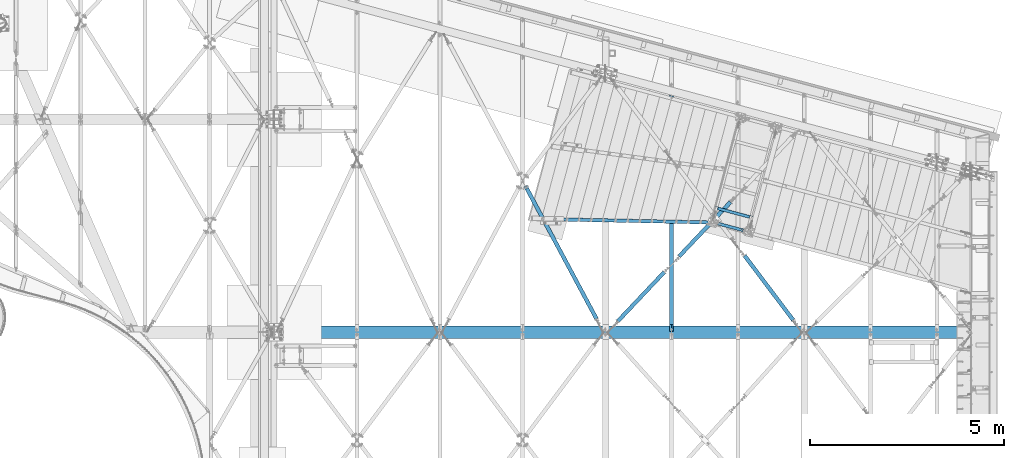
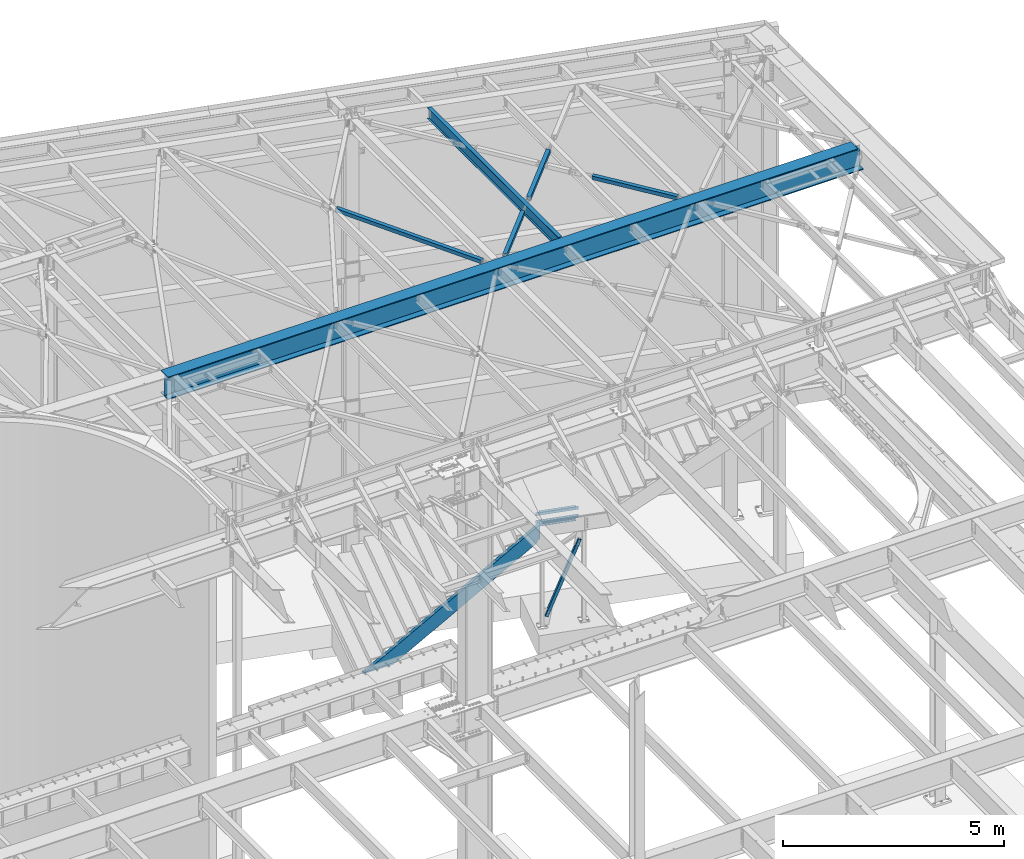
# One storey, part 1167 of 1763: 8 beams, 2 members, 9 elements without a shape of their own.
"""IFC2X3 building model written with IfcOpenShell, lengths in millimetres."""

import ifcopenshell
import ifcopenshell.guid

model = None  # the IFC model being written
_history = None  # IfcOwnerHistory: only IFC2X3 demands one
_inside = {}  # id of a spatial element -> (the spatial element, [elements in it])
_under = {}  # id of a project, library or spatial element -> (it, [spatial elements below it])
_declared = {}  # id of a project -> (the project, [libraries it declares])
_typed = {}  # id of a type object -> (the type object, [elements of that type])
_made_of = {}  # id of a material, layer set ... -> (it, [elements and type objects made of it])


def new_model(schema):
    """Start an empty IFC model of exactly this schema.

    Asked for "IFC4X3", IfcOpenShell would pick the latest addendum, in which some entities
    have other attributes; the version numbers below select the first issue.
    IFC2X3 requires an IfcOwnerHistory on every rooted entity: one is made here for all.
    """
    global model, _history
    if schema == "IFC4X3":
        model = ifcopenshell.file(schema_version=(4, 3, 0, 0))
    else:
        model = ifcopenshell.file(schema=schema)
    _inside.clear()
    _under.clear()
    _declared.clear()
    _typed.clear()
    _made_of.clear()
    _history = None
    if model.schema == "IFC2X3":
        org = make("IfcOrganization", Name="unknown")
        user = make(
            "IfcPersonAndOrganization",
            ThePerson=make("IfcPerson", FamilyName="unknown"),
            TheOrganization=org,
        )
        app = make(
            "IfcApplication",
            ApplicationDeveloper=org,
            Version="unknown",
            ApplicationFullName="unknown",
            ApplicationIdentifier="unknown",
        )
        _history = make(
            "IfcOwnerHistory",
            OwningUser=user,
            OwningApplication=app,
            ChangeAction="ADDED",
            CreationDate=0,
        )
    return model


def make(cls, **values):
    """One entity of the class cls with the attributes given. An attribute that is None is left unset."""
    return model.create_entity(
        cls, **{name: value for name, value in values.items() if value is not None}
    )


def rooted(cls, **values):
    """An entity with a GlobalId (a new one), such as an element, a storey or a relation."""
    return make(cls, GlobalId=ifcopenshell.guid.new(), OwnerHistory=_history, **values)


def si_unit(unit_type, name, prefix=None):
    """IfcSIUnit, for example si_unit("LENGTHUNIT", "METRE", prefix="MILLI")."""
    return make("IfcSIUnit", UnitType=unit_type, Prefix=prefix, Name=name)


def assignment(units):
    """IfcUnitAssignment: the units of a project."""
    return None if units is None else make("IfcUnitAssignment", Units=units)


def point(xyz):
    """IfcCartesianPoint."""
    return None if xyz is None else make("IfcCartesianPoint", Coordinates=xyz)


def direction(xyz):
    """IfcDirection."""
    return None if xyz is None else make("IfcDirection", DirectionRatios=xyz)


def frame(location, z_axis=None, x_axis=None):
    """IfcAxis2Placement3D, a coordinate frame: its origin and axes. An axis left out is left unset."""
    return make(
        "IfcAxis2Placement3D",
        Location=point(location),
        Axis=direction(z_axis),
        RefDirection=direction(x_axis),
    )


def origin_with_axes():
    """The frame at (0, 0, 0) with the z axis (0, 0, 1) and the x axis (1, 0, 0) written out."""
    return frame((0.0, 0.0, 0.0), z_axis=(0.0, 0.0, 1.0), x_axis=(1.0, 0.0, 0.0))


def place(relative_to, where):
    """IfcLocalPlacement: puts the frame where relative to a parent placement (None: the world)."""
    return make(
        "IfcLocalPlacement", PlacementRelTo=relative_to, RelativePlacement=where
    )


def context(
    kind, dimensions, precision=None, world=None, true_north=None, identifier=None
):
    """IfcGeometricRepresentationContext, for example the 3D "Model" context."""
    return make(
        "IfcGeometricRepresentationContext",
        ContextIdentifier=identifier,
        ContextType=kind,
        CoordinateSpaceDimension=dimensions,
        Precision=precision,
        WorldCoordinateSystem=world,
        TrueNorth=true_north,
    )


def subcontext(parent, identifier, kind, view, scale=None):
    """IfcGeometricRepresentationSubContext, for example "Body" below "Model"."""
    return make(
        "IfcGeometricRepresentationSubContext",
        ContextIdentifier=identifier,
        ContextType=kind,
        ParentContext=parent,
        TargetScale=scale,
        TargetView=view,
    )


def project(units=None, contexts=None):
    """IfcProject with its units and contexts."""
    return rooted(
        "IfcProject",
        Name="project",
        RepresentationContexts=contexts,
        UnitsInContext=assignment(units),
    )


def spatial(cls, under=None, at=None, **own):
    """A site, building, storey or space (cls), placed at a placement, below another one or the project."""
    s = rooted(cls, ObjectPlacement=at, **own)
    if under is not None:
        _under.setdefault(under.id(), (under, []))[1].append(s)
    return s


def faces_of(points, faces, orient=None, outer=None):
    """IfcFace entities. A face is a list of loops; a loop is a list of indices into points, from 0.

    orient and outer hold one flag for each loop. By default every Orientation is true, the
    first loop of a face is its IfcFaceOuterBound and the others are IfcFaceBound.
    """
    made = []
    for i, loops in enumerate(faces):
        bounds = []
        for j, loop in enumerate(loops):
            is_outer = j == 0 if outer is None else outer[i][j]
            bounds.append(
                make(
                    "IfcFaceOuterBound" if is_outer else "IfcFaceBound",
                    Bound=make("IfcPolyLoop", Polygon=[points[k] for k in loop]),
                    Orientation=True if orient is None else orient[i][j],
                )
            )
        made.append(make("IfcFace", Bounds=bounds))
    return made


def faceted_brep(points, faces, orient=None, outer=None, voids=None):
    """IfcFacetedBrep: a solid bounded by flat faces; with voids (closed shells), ...WithVoids."""
    shared = [point(p) for p in points]
    hull = make("IfcClosedShell", CfsFaces=faces_of(shared, faces, orient, outer))
    if voids is None:
        return make("IfcFacetedBrep", Outer=hull)
    return make(
        "IfcFacetedBrepWithVoids",
        Outer=hull,
        Voids=[
            make(cls, CfsFaces=faces_of(shared, fs, o, b)) for cls, fs, o, b in voids
        ],
    )


def shape(context_of_items, identifier, shape_type, items):
    """IfcShapeRepresentation: the items that make up one representation, for example the "Body"."""
    return make(
        "IfcShapeRepresentation",
        ContextOfItems=context_of_items,
        RepresentationIdentifier=identifier,
        RepresentationType=shape_type,
        Items=items,
    )


def material(Name=None, Category=None):
    """IfcMaterial."""
    return make("IfcMaterial", Name=Name, Category=Category)


def made_of(thing, what):
    """Note that an element or type object is made of a material, layer set ...; save() writes the relation."""
    if what is not None:
        _made_of.setdefault(what.id(), (what, []))[1].append(thing)
    return thing


def type_object(cls, material=None, **own):
    """A type object (cls), such as IfcWallType, which elements share."""
    return made_of(rooted(cls, **own), material)


def element(
    cls,
    number,
    at=None,
    inside=None,
    cuts=None,
    type_object=None,
    material=None,
    context=None,
    identifier="Body",
    shape_type=None,
    held_by="IfcProductDefinitionShape",
    body=None,
    shapes=None,
    **own,
):
    """One element of the class cls, such as IfcWall. Its Tag is "e" and its number.

    at: its placement. inside: the storey or other place that contains it. cuts: it is an
    opening in that element (IfcRelVoidsElement). A single representation is given by context,
    identifier, shape_type and body (its items); several are given by shapes. held_by: the class
    of the entity that holds the representations. save() writes the other relations.
    """
    e = rooted(cls, Tag="e%d" % number, ObjectPlacement=at, **own)
    if body is not None:
        shapes = [shape(context, identifier, shape_type, body)]
    if shapes is not None:
        e.Representation = make(held_by, Representations=shapes)
    if inside is not None:
        _inside.setdefault(inside.id(), (inside, []))[1].append(e)
    if cuts is not None:
        rooted(
            "IfcRelVoidsElement", RelatingBuildingElement=cuts, RelatedOpeningElement=e
        )
    if type_object is not None:
        _typed.setdefault(type_object.id(), (type_object, []))[1].append(e)
    return made_of(e, material)


def aggregate(whole, parts):
    """IfcRelAggregates: a whole, such as a stair, and the parts it consists of."""
    return rooted("IfcRelAggregates", RelatingObject=whole, RelatedObjects=parts)


def save(model, path):
    """Write the relations noted so far, then the file.

    IfcRelAggregates (storeys below a building ...), IfcRelContainedInSpatialStructure (elements
    in a storey), IfcRelDefinesByType, IfcRelAssociatesMaterial and IfcRelDeclares: one each for
    every whole, place, type object, material and project.
    """
    for whole, parts in _under.values():
        aggregate(whole, parts)
    for where, things in _inside.values():
        rooted(
            "IfcRelContainedInSpatialStructure",
            RelatedElements=things,
            RelatingStructure=where,
        )
    for kind, things in _typed.values():
        rooted("IfcRelDefinesByType", RelatedObjects=things, RelatingType=kind)
    for what, things in _made_of.values():
        rooted("IfcRelAssociatesMaterial", RelatedObjects=things, RelatingMaterial=what)
    for by, libraries in _declared.values():
        rooted("IfcRelDeclares", RelatingContext=by, RelatedDefinitions=libraries)
    model.write(path)


model = new_model("IFC2X3")

# Units and contexts
model_context = context("Model", 3, precision=1e-05, world=origin_with_axes())
body_context = subcontext(model_context, "Body", "Model", "MODEL_VIEW")
ifc_project = project(units=[si_unit("LENGTHUNIT", "METRE", prefix="MILLI"), si_unit("AREAUNIT", "SQUARE_METRE"), si_unit("VOLUMEUNIT", "CUBIC_METRE"), si_unit("MASSUNIT", "GRAM", prefix="KILO"), si_unit("TIMEUNIT", "SECOND"), si_unit("PLANEANGLEUNIT", "RADIAN"), si_unit("SOLIDANGLEUNIT", "STERADIAN"), si_unit("THERMODYNAMICTEMPERATUREUNIT", "DEGREE_CELSIUS"), si_unit("LUMINOUSINTENSITYUNIT", "LUMEN")], contexts=[model_context])

# Site, building, storey
site_placement = place(None, origin_with_axes())
site = spatial("IfcSite", under=ifc_project, at=site_placement, CompositionType="ELEMENT")
building_placement = place(site_placement, origin_with_axes())
building = spatial("IfcBuilding", under=site, at=building_placement, Name="Undefined", CompositionType="ELEMENT")
storey_placement = place(building_placement, origin_with_axes())
storey = spatial("IfcBuildingStorey", under=building, at=storey_placement, Name="Undefined", CompositionType="ELEMENT", Elevation=0.0)

# Assembly, beams
assembly_1_placement = place(storey_placement, origin_with_axes())
assembly_1 = element("IfcElementAssembly", 1, at=assembly_1_placement, inside=storey, Name="FRAME", AssemblyPlace="NOTDEFINED", PredefinedType="RIGID_FRAME")
ifc_material_1 = material(Name="STEEL/A36")
beam_type_1 = type_object("IfcBeamType", Name="L5X3X1/4", PredefinedType="NOTDEFINED")
beam_1_placement = place(assembly_1_placement, frame((-28295.2458332206, 60921.4478343345, 2311.40000009092), z_axis=(0.0, 0.0, 1.0), x_axis=(0.965913267114843, -0.258865912030785, 0.0)))
beam_1 = element("IfcBeam", 2, at=beam_1_placement, type_object=beam_type_1, material=ifc_material_1, Name="ANGLE", ObjectType="L5X3X1/4", context=body_context, shape_type="Brep", body=[
    faceted_brep([(85.7250002993387, -38.0999999998603, -57.1500000000001), (92.0750017297105, -38.0999999998603, -63.499999957723), (935.037468048155, -38.0999999993292, -63.4999999958368), (941.387469479872, -38.0999999993292, -57.1500001000077), (92.0750019702682, 38.099999999984, -63.5), (935.037468215283, 38.1000000005079, -63.5), (949.227390314394, 31.7500000005311, -26.3667318659031), (949.22739032832, 38.1000000005151, -26.3667318659031), (954.087470019935, 38.1000000005224, -25.4000021055181), (954.087470006009, 31.7500000005311, -25.4000021055181), (945.107213654439, 31.7500000005239, -29.1197457287767), (945.107213668365, 38.1000000005079, -29.1197457287767), (942.354199608213, 31.7500000005239, -33.239922266207), (942.354199622132, 38.1000000005151, -33.239922266207), (941.387469631547, 31.7500000005239, -38.1000019147832), (941.387469645473, 38.1000000005079, -38.1000019147832), (941.387469631416, 31.7500000005239, -57.1500000000001), (941.387469645473, 38.1000000005079, -57.1500001197246), (85.7250005197857, 31.7499999999927, -57.1500000000001), (85.7250005398237, 38.0999999999694, -57.1500000397209), (85.7250005197711, 31.7499999999927, -38.1000018544964), (85.7250005398237, 38.0999999999694, -38.1000018544964), (84.7582705431123, 31.7499999999854, -33.2399222059203), (84.7582705631648, 38.0999999999694, -33.2399222059203), (82.0052564968937, 31.7499999999782, -29.1197456684899), (82.005256516939, 38.0999999999694, -29.1197456684899), (77.8850798369385, 31.7499999999854, -26.3667318056164), (77.8850798569911, 38.0999999999767, -26.3667318056164), (73.0250001453314, 31.7499999999854, -25.4000020452313), (73.0250001653767, 38.0999999999694, -25.4000020452313), (9.52500204597163, 31.7499999999345, -25.4000048709327), (9.52500206602417, 38.0999999999258, -25.4000048709327), (9.52500204597163, 31.7499999999345, 63.5), (9.52500206602417, 38.0999999999258, 63.5), (1017.58746719851, 31.7500000005748, 63.5), (1017.58746721857, 38.1000000005588, 63.5), (1017.58746721857, 38.1000000005588, -25.400004931219), (1017.58746719851, 31.7500000005748, -25.4000049312194)], [[[0, 1, 2, 3]], [[1, 4, 5, 2]], [[6, 7, 8, 9]], [[10, 11, 7, 6]], [[12, 13, 11, 10]], [[14, 15, 13, 12]], [[15, 14, 16, 17]], [[3, 2, 5, 17, 16]], [[18, 0, 3, 16]], [[1, 0, 18, 19, 4]], [[20, 21, 19, 18]], [[22, 23, 21, 20]], [[24, 25, 23, 22]], [[26, 27, 25, 24]], [[28, 29, 27, 26]], [[29, 28, 30, 31]], [[31, 30, 32, 33]], [[33, 32, 34, 35]], [[8, 7, 11, 13, 15, 17, 5, 4, 19, 21, 23, 25, 27, 29, 31, 33, 35, 36]], [[9, 8, 36, 37]], [[32, 30, 28, 26, 24, 22, 20, 18, 16, 14, 12, 10, 6, 9, 37, 34]], [[36, 35, 34, 37]]]),
])
beam_2_placement = place(assembly_1_placement, frame((-27303.1442619046, 60655.5634284535, 2565.40000005935), z_axis=(0.0, 0.0, -1.0), x_axis=(-0.965913267114846, 0.258865912030774, 0.0)))
beam_2 = element("IfcBeam", 3, at=beam_2_placement, type_object=beam_type_1, material=ifc_material_1, Name="ANGLE", ObjectType="L5X3X1/4", context=body_context, shape_type="Brep", body=[
    faceted_brep([(85.7250002993387, -38.0999999998603, -57.1500000000001), (92.0750017297105, -38.0999999998603, -63.499999957723), (935.037468048155, -38.0999999993292, -63.4999999958368), (941.387469479872, -38.0999999993292, -57.1500001000077), (85.7250005197857, 31.7499999999927, -57.1500000000001), (941.387469631416, 31.7500000005239, -57.1500000000001), (73.0250001453314, 31.7499999999854, -25.4000020452313), (73.0250001653767, 38.0999999999694, -25.4000020452313), (77.8850798569911, 38.0999999999767, -26.3667318056164), (77.8850798369385, 31.7499999999854, -26.3667318056164), (82.005256516939, 38.0999999999694, -29.1197456684899), (82.0052564968937, 31.7499999999782, -29.1197456684899), (84.7582705631648, 38.0999999999694, -33.2399222059203), (84.7582705431123, 31.7499999999854, -33.2399222059203), (85.7250005398237, 38.0999999999694, -38.1000018544964), (85.7250005197711, 31.7499999999927, -38.1000018544964), (85.7250005398237, 38.0999999999694, -57.1500000397209), (92.0750019702682, 38.099999999984, -63.5), (935.037468215283, 38.1000000005079, -63.5), (941.387469645473, 38.1000000005079, -57.1500001197246), (941.387469645473, 38.1000000005079, -38.1000019147832), (941.387469631547, 31.7500000005239, -38.1000019147832), (942.354199622132, 38.1000000005151, -33.239922266207), (942.354199608213, 31.7500000005239, -33.239922266207), (945.107213668365, 38.1000000005079, -29.1197457287767), (945.107213654439, 31.7500000005239, -29.1197457287767), (949.22739032832, 38.1000000005151, -26.3667318659031), (949.227390314394, 31.7500000005311, -26.3667318659031), (954.087470019935, 38.1000000005224, -25.4000021055181), (954.087470006009, 31.7500000005311, -25.4000021055181), (1017.58746721857, 38.1000000005588, -25.400004931219), (1017.58746719851, 31.7500000005748, -25.4000049312194), (1017.58746721857, 38.1000000005588, 63.5), (1017.58746719851, 31.7500000005748, 63.5), (9.52500204597163, 31.7499999999345, 63.5), (9.52500204597163, 31.7499999999345, -25.4000048709327), (9.52500206602417, 38.0999999999258, -25.4000048709327), (9.52500206602417, 38.0999999999258, 63.5)], [[[0, 1, 2, 3]], [[4, 0, 3, 5]], [[6, 7, 8, 9]], [[9, 8, 10, 11]], [[11, 10, 12, 13]], [[13, 12, 14, 15]], [[15, 14, 16, 4]], [[1, 0, 4, 16, 17]], [[1, 17, 18, 2]], [[3, 2, 18, 19, 5]], [[20, 21, 5, 19]], [[21, 20, 22, 23]], [[23, 22, 24, 25]], [[25, 24, 26, 27]], [[27, 26, 28, 29]], [[29, 28, 30, 31]], [[30, 32, 33, 31]], [[34, 35, 6, 9, 11, 13, 15, 4, 5, 21, 23, 25, 27, 29, 31, 33]], [[7, 6, 35, 36]], [[28, 26, 24, 22, 20, 19, 18, 17, 16, 14, 12, 10, 8, 7, 36, 37, 32, 30]], [[37, 34, 33, 32]], [[36, 35, 34, 37]]]),
])
aggregate(assembly_1, [beam_1, beam_2])

# Assembly, beam
assembly_2_placement = place(storey_placement, origin_with_axes())
assembly_2 = element("IfcElementAssembly", 4, at=assembly_2_placement, inside=storey, Name="H. BRACE", AssemblyPlace="NOTDEFINED", PredefinedType="RIGID_FRAME")
ifc_material_2 = material()
beam_type_2 = type_object("IfcBeamType", Name="HSS4X4X3/8", PredefinedType="NOTDEFINED")
beam_3_placement = place(assembly_2_placement, frame((-29400.5296174484, 59455.8084650396, 12371.3875), z_axis=(0.0, 0.0, 1.0), x_axis=(-0.687068110981766, -0.726593015980713, 0.0)))
beam_3 = element("IfcBeam", 5, at=beam_3_placement, type_object=beam_type_2, material=ifc_material_2, Name="H. BRACE", ObjectType="HSS4X4X3/8", context=body_context, shape_type="Brep", body=[
    faceted_brep([(280.080500516084, 41.274999999041, -41.2749999999996), (280.080500516509, -41.2750000008455, -41.2749999999996), (2025.15088479734, -41.2750000064916, -41.2749999999996), (2025.15088479691, 41.2749999933949, -41.2749999999996), (280.080500516509, -41.2750000008455, 41.2749999999996), (2025.15088479734, -41.2750000064916, 41.2749999999996), (280.080500516084, 41.274999999041, 41.2749999999996), (2025.15088479691, 41.2749999933949, 41.2749999999996), (280.080500516036, 50.7999999990279, -50.7999999999993), (280.080500516036, 50.7999999990279, 50.7999999999993), (2025.15088479687, 50.7999999933891, 50.7999999999993), (2025.15088479687, 50.7999999933891, -50.7999999999993), (280.080500516553, -50.8000000008396, 50.7999999999993), (2025.15088479738, -50.8000000064858, 50.7999999999993), (280.080500516553, -50.8000000008396, -50.7999999999993), (2025.15088479738, -50.8000000064858, -50.7999999999993)], [[[0, 1, 2, 3]], [[1, 4, 5, 2]], [[4, 6, 7, 5]], [[6, 0, 3, 7]], [[8, 9, 10, 11]], [[9, 12, 13, 10]], [[12, 14, 15, 13]], [[14, 8, 11, 15]], [[13, 15, 11, 10], [5, 7, 3, 2]], [[14, 12, 9, 8], [6, 4, 1, 0]]]),
])
aggregate(assembly_2, [beam_3])

assembly_3_placement = place(storey_placement, origin_with_axes())
assembly_3 = element("IfcElementAssembly", 6, at=assembly_3_placement, inside=storey, Name="H. BRACE", AssemblyPlace="NOTDEFINED", PredefinedType="RIGID_FRAME")
beam_4_placement = place(assembly_3_placement, frame((-27688.5696174484, 61266.2522329229, 12371.3875), z_axis=(0.0, 0.0, 1.0), x_axis=(-0.687068110981766, -0.726593015980713, 0.0)))
beam_4 = element("IfcBeam", 7, at=beam_4_placement, type_object=beam_type_2, material=ifc_material_2, Name="H. BRACE", ObjectType="HSS4X4X3/8", context=body_context, shape_type="Brep", body=[
    faceted_brep([(769.453047632549, 50.7999999974418, 6.35000000000218), (767.846995725602, 41.2749999974549, 6.35000000000218), (767.846995725602, 41.2749999974549, -6.34999999999854), (769.453047632549, 50.7999999974418, -6.34999999999854), (909.51898257486, 41.2749999970038, -6.34999999999854), (911.125034508874, 50.7999999969834, -6.34999999999854), (909.51898257486, 41.2749999970038, 6.35000000000218), (911.125034508874, 50.7999999969834, 6.35000000000218), (753.927879198742, -41.275000002388, 6.35000000000218), (752.321827291798, -50.8000000023676, 6.35000000000218), (752.321827291798, -50.8000000023676, -6.34999999999854), (753.927879198742, -41.275000002388, -6.34999999999854), (893.993813879457, -50.8000000028187, -6.34999999999854), (895.599865813463, -41.2750000028464, -6.34999999999854), (893.993813879457, -50.8000000028187, 6.35000000000218), (895.599865813463, -41.2750000028464, 6.35000000000218), (280.080500516553, -50.8000000008396, -50.7999999999993), (280.080500516036, 50.7999999990279, -50.7999999999993), (2211.11705794657, 50.7999999927852, -50.7999999999993), (2211.11705794709, -50.8000000070824, -50.7999999999993), (280.080500516036, 50.7999999990279, 50.7999999999993), (280.080500516553, -50.8000000008396, 50.7999999999993), (2211.11705794709, -50.8000000070824, 50.7999999999993), (2211.11705794657, 50.7999999927852, 50.7999999999993), (280.080500516084, 41.274999999041, 41.2749999999996), (280.080500516509, -41.2750000008455, 41.2749999999996), (280.080500516509, -41.2750000008455, -41.2749999999996), (280.080500516084, 41.274999999041, -41.2749999999996), (2211.11705794662, 41.274999992791, -41.2749999999996), (2211.11705794662, 41.274999992791, 41.2749999999996), (2211.11705794704, -41.2750000071028, 41.2749999999996), (2211.11705794704, -41.2750000071028, -41.2749999999996)], [[[0, 1, 2, 3]], [[3, 2, 4, 5]], [[5, 4, 6, 7]], [[7, 6, 1, 0]], [[8, 9, 10, 11]], [[11, 10, 12, 13]], [[13, 12, 14, 15]], [[15, 14, 9, 8]], [[16, 17, 18, 19]], [[20, 21, 22, 23]], [[17, 20, 23, 18], [3, 5, 7, 0]], [[16, 21, 20, 17], [24, 25, 26, 27]], [[24, 27, 28, 29], [2, 1, 6, 4]], [[25, 24, 29, 30]], [[26, 25, 30, 31], [11, 13, 15, 8]], [[27, 26, 31, 28]], [[22, 19, 18, 23], [30, 29, 28, 31]], [[21, 16, 19, 22], [10, 9, 14, 12]]]),
])
aggregate(assembly_3, [beam_4])

assembly_4_placement = place(storey_placement, origin_with_axes())
assembly_4 = element("IfcElementAssembly", 8, at=assembly_4_placement, inside=storey, Name="H. BRACE", AssemblyPlace="NOTDEFINED", PredefinedType="RIGID_FRAME")
beam_5_placement = place(assembly_4_placement, frame((-31160.1096149185, 57702.4499981051, 12371.3875), z_axis=(0.0, 0.0, 1.0), x_axis=(-0.471735585214394, 0.881740062400724, 0.0)))
beam_5 = element("IfcBeam", 9, at=beam_5_placement, type_object=beam_type_2, material=ifc_material_2, Name="H. BRACE", ObjectType="HSS4X4X3/8", context=body_context, shape_type="Brep", body=[
    faceted_brep([(4279.86072570054, 6.34999744098613, 50.7999999999993), (4202.0732259301, 6.35000001750822, 50.7999999999993), (4202.0732259301, 6.35000001750822, 41.2749999999996), (4279.86072570054, 6.34999744098613, 41.2749999999996), (4202.07322550952, -6.34999998249614, 50.7999999999993), (4202.07322550952, -6.34999998249614, 41.2749999999996), (4279.86072570054, -6.35000255898913, 50.7999999999993), (4279.86072570054, -6.35000255898913, 41.2749999999996), (4279.86072570054, 6.34999744098613, -41.2749999999996), (4202.0732259301, 6.35000001750822, -41.2749999999996), (4202.0732259301, 6.35000001750822, -50.7999999999993), (4279.86072570054, 6.34999744098613, -50.7999999999993), (4202.07322550952, -6.34999998249614, -41.2749999999996), (4202.07322550952, -6.34999998249614, -50.7999999999993), (4279.86072570054, -6.35000255898913, -41.2749999999996), (4279.86072570054, -6.35000255898913, -50.7999999999993), (387.128876200542, 41.2749999987828, 41.2749999999996), (387.128876200542, 41.2749999987828, -41.2749999999996), (4279.86072570048, 41.2749999868939, -41.2749999999996), (4279.86072570048, 41.2749999868939, 41.2749999999996), (4279.86072570061, -41.2750000130326, 41.2749999999996), (387.128876200688, -41.2750000011473, 41.2749999999996), (387.128876200688, -41.2750000011473, -41.2749999999996), (4279.86072570061, -41.2750000130326, -41.2749999999996), (387.128876200703, -50.8000000011342, -50.7999999999993), (387.128876200703, -50.8000000011342, 50.7999999999993), (387.128876200528, 50.7999999987697, 50.7999999999993), (387.128876200528, 50.7999999987697, -50.7999999999993), (4279.86072570045, 50.7999999868844, 50.7999999999993), (4279.86072570045, 50.7999999868844, -50.7999999999993), (4279.86072570062, -50.8000000130232, -50.7999999999993), (4279.86072570062, -50.8000000130232, 50.7999999999993)], [[[0, 1, 2, 3]], [[4, 5, 2, 1]], [[6, 7, 5, 4]], [[8, 9, 10, 11]], [[12, 13, 10, 9]], [[14, 15, 13, 12]], [[16, 17, 18, 19]], [[20, 21, 16, 19, 3, 2, 5, 7]], [[22, 21, 20, 23]], [[9, 8, 18, 17, 22, 23, 14, 12]], [[24, 25, 26, 27], [16, 21, 22, 17]], [[27, 26, 28, 29]], [[19, 18, 8, 11, 29, 28, 0, 3]], [[30, 24, 27, 29, 11, 10, 13, 15]], [[25, 24, 30, 31]], [[1, 0, 28, 26, 25, 31, 6, 4]], [[31, 30, 15, 14, 23, 20, 7, 6]]]),
])
aggregate(assembly_4, [beam_5])

assembly_5_placement = place(storey_placement, origin_with_axes())
assembly_5 = element("IfcElementAssembly", 10, at=assembly_5_placement, inside=storey, Name="H. BRACE", AssemblyPlace="NOTDEFINED", PredefinedType="RIGID_FRAME")
beam_6_placement = place(assembly_5_placement, frame((-26027.4096194441, 57702.4499984928, 12371.3875), z_axis=(0.0, 0.0, 1.0), x_axis=(-0.602242336837067, 0.798313326784057, 0.0)))
beam_6 = element("IfcBeam", 11, at=beam_6_placement, type_object=beam_type_2, material=ifc_material_2, Name="H. BRACE", ObjectType="HSS4X4X3/8", context=body_context, shape_type="Brep", body=[
    faceted_brep([(387.433986057615, 41.2750000000342, -41.2749999999996), (387.433986057375, -41.2749999998414, -41.2749999999996), (2476.90561113742, -41.2749999993393, -41.2749999999996), (2476.90561113766, 41.2750000005362, -41.2749999999996), (387.433986057375, -41.2749999998414, 41.2749999999996), (2476.90561113742, -41.2749999993393, 41.2749999999996), (387.433986057615, 41.2750000000342, 41.2749999999996), (2476.90561113766, 41.2750000005362, 41.2749999999996), (387.433986057644, 50.8000000000175, -50.7999999999993), (387.433986057644, 50.8000000000175, 50.7999999999993), (2476.90561113768, 50.8000000005231, 50.7999999999993), (2476.90561113768, 50.8000000005231, -50.7999999999993), (387.433986057345, -50.7999999998246, 50.7999999999993), (2476.90561113739, -50.7999999993226, 50.7999999999993), (387.433986057345, -50.7999999998246, -50.7999999999993), (2476.90561113739, -50.7999999993226, -50.7999999999993)], [[[0, 1, 2, 3]], [[1, 4, 5, 2]], [[4, 6, 7, 5]], [[6, 0, 3, 7]], [[8, 9, 10, 11]], [[9, 12, 13, 10]], [[12, 14, 15, 13]], [[14, 8, 11, 15]], [[13, 15, 11, 10], [5, 7, 3, 2]], [[14, 12, 9, 8], [6, 4, 1, 0]]]),
])
aggregate(assembly_5, [beam_6])

# Assembly, member
assembly_6_placement = place(storey_placement, origin_with_axes())
assembly_6 = element("IfcElementAssembly", 12, at=assembly_6_placement, inside=storey, Name="STRINGER", AssemblyPlace="NOTDEFINED", PredefinedType="RIGID_FRAME")
member_type_1 = type_object("IfcMemberType", Name="C15X33.9", PredefinedType="NOTDEFINED")
member_1_placement = place(assembly_6_placement, frame((-33063.0968571892, 60628.997279088, -251.313030729987), z_axis=(0.492735582494082, -0.00948887898989051, -0.870127350977851), x_axis=(0.869949407028361, -0.0176014450005736, 0.492826763016067)))
member_1 = element("IfcMember", 13, at=member_1_placement, type_object=member_type_1, material=ifc_material_1, Name="STRINGER", ObjectType="C15X33.9", context=body_context, shape_type="Brep", body=[
    faceted_brep([(5442.12869488743, 42.8624999808162, -190.499999991411), (5466.43053217413, -42.8625000191241, -190.499999991403), (192.888983285073, -42.8625000006214, -190.499999999447), (192.961694872552, 42.8624999992317, -190.499999999418), (5461.4848573535, -42.8625000191096, -181.765892491421), (208.309789119019, -42.8625000006723, -181.765892499432), (5432.69474545635, 33.337499980873, -169.07097249146), (230.788377090856, 33.3374999991283, -169.070972499394), (5250.66230603547, 33.3374999815424, 152.400000034606), (5162.17961344163, 33.3374999818552, 152.400000034886), (5157.31953392355, 33.3374999818625, 153.366729957477), (5153.19935745538, 33.337499981877, 156.119743857962), (5150.44634355489, 33.3374999818843, 160.239920326116), (5149.4796136323, 33.3374999818916, 165.099999844158), (5149.4796136329, 33.3374999818989, 169.070972507616), (827.806593108424, 33.337499997062, 169.070972501024), (5149.47961363266, -42.8625000179745, 181.765892507574), (850.155916035863, -42.8625000028842, 181.765892501015), (5149.47961363268, -42.8625000179745, 190.50000000756), (865.576721869802, -42.8625000029424, 190.500000001026), (5149.47961363298, 42.8624999818785, 190.500000007589), (865.649433457278, 42.8624999969179, 190.500000001051), (5149.47961363227, 42.8624999818785, 165.099999843973), (5150.44634355486, 42.8624999818785, 160.239920325927), (5153.19935745535, 42.8624999818567, 156.119743857773), (5157.31953392352, 42.8624999818567, 153.366729957288), (5162.1796134416, 42.8624999818348, 152.400000034693), (5247.96210189262, 42.8624999815365, 152.400000034402)], [[[0, 1, 2, 3]], [[1, 4, 5, 2]], [[4, 6, 7, 5]], [[6, 8, 9, 10, 11, 12, 13, 14, 15, 7]], [[14, 16, 17, 15]], [[16, 18, 19, 17]], [[18, 20, 21, 19]], [[3, 2, 5, 7, 15, 17, 19, 21]], [[20, 22, 23, 24, 25, 26, 27, 0, 3, 21]], [[18, 16, 14, 13, 22, 20]], [[12, 23, 22, 13]], [[11, 24, 23, 12]], [[10, 25, 24, 11]], [[9, 26, 25, 10]], [[8, 27, 26, 9]], [[6, 4, 1, 0, 27, 8]]]),
])
aggregate(assembly_6, [member_1])

# Assembly, beam
assembly_7_placement = place(storey_placement, origin_with_axes())
assembly_7 = element("IfcElementAssembly", 14, at=assembly_7_placement, inside=storey, Name="BEAM", AssemblyPlace="NOTDEFINED", PredefinedType="RIGID_FRAME")
ifc_material_3 = material(Name="STEEL/A992")
beam_type_3 = type_object("IfcBeamType", Name="W12X16", PredefinedType="NOTDEFINED")
beam_7_placement = place(assembly_7_placement, frame((-29400.5296174484, 57702.45, 12293.6), z_axis=(0.0, 0.0, 1.0), x_axis=(0.0, 1.0, 0.0)))
beam_7 = element("IfcBeam", 15, at=beam_7_placement, type_object=beam_type_3, material=ifc_material_3, Name="BEAM", ObjectType="W12X16", context=body_context, shape_type="Brep", body=[
    faceted_brep([(20.637499999335, -3.17500000023574, -146.050000000019), (20.637499999335, -50.8000000002503, -146.05000000003), (6094.69888715117, -50.7999999999993, -146.049999999999), (6107.45996743946, -3.17499999999927, -146.049999999999), (20.637499999335, -50.8000000002576, -152.400000000032), (6094.69888715117, -50.7999999999993, -152.4), (20.637499999335, 50.7999999997701, -152.400000000003), (6121.92252509953, 50.7999999999993, -152.4), (20.637499999335, 50.7999999997774, -146.050000000005), (6121.92252509953, 50.7999999999993, -146.049999999999), (6109.16144481124, 3.17499999999927, -146.049999999999), (6109.16144481124, 3.17499999999927, 146.049999999999), (6121.92252509953, 50.7999999999993, 146.049999999999), (6121.92252509953, 50.7999999999993, 152.4), (6094.69888715117, -50.7999999999993, 152.4), (6094.69888715117, -50.7999999999993, 146.049999999999), (6107.45996743946, -3.17499999999927, 146.049999999999), (20.637499999335, 3.17499999977008, -146.050000000016), (184.247579708775, -3.17500000000291, 115.006731601054), (184.247579708775, 3.17500000000291, 115.006731601054), (179.387500190729, 3.17500000000291, 114.040001678466), (179.387500190729, -3.17500000000291, 114.040001678466), (188.367756176929, -3.17500000000291, 117.759745501531), (188.367756176929, 3.17500000000291, 117.759745501531), (191.120770077403, -3.17500000000291, 121.879921969685), (191.120770077403, 3.17500000000291, 121.879921969685), (192.087499999994, -3.17500000000291, 126.740001487731), (192.087499999994, 3.17500000000291, 126.740001487731), (20.6374999999971, 3.17500000000291, 114.040001678466), (192.087499999994, 3.17500000000291, 146.049999999999), (192.087499999994, 50.8000000000029, 146.049999999999), (192.087499999994, 50.8000000000029, 152.4), (192.087499999994, -50.8000000000029, 152.4), (192.087499999994, -50.8000000000029, 146.049999999999), (192.087499999994, -3.17500000000291, 146.049999999999), (20.6374999999971, -3.17500000000291, 114.040001678466)], [[[0, 1, 2, 3]], [[1, 4, 5, 2]], [[4, 6, 7, 5]], [[6, 8, 9, 7]], [[10, 11, 12, 13, 14, 15, 16, 3, 2, 5, 7, 9]], [[8, 17, 10, 9]], [[18, 19, 20, 21]], [[22, 23, 19, 18]], [[24, 25, 23, 22]], [[26, 27, 25, 24]], [[11, 10, 17, 28, 20, 19, 23, 25, 27, 29]], [[12, 11, 29, 30]], [[13, 12, 30, 31]], [[14, 13, 31, 32]], [[15, 14, 32, 33]], [[16, 15, 33, 34]], [[32, 31, 30, 29, 27, 26, 34, 33]], [[24, 22, 18, 21, 35, 0, 3, 16, 34, 26]], [[17, 8, 6, 4, 1, 0, 35, 28]], [[21, 20, 28, 35]]]),
])
aggregate(assembly_7, [beam_7])

# Assembly, member
assembly_8_placement = place(storey_placement, origin_with_axes())
assembly_8 = element("IfcElementAssembly", 16, at=assembly_8_placement, inside=storey, Name="BRACE", AssemblyPlace="NOTDEFINED", PredefinedType="RIGID_FRAME")
member_type_2 = type_object("IfcMemberType", Name="HSS3X3X1/4", PredefinedType="NOTDEFINED")
member_2_placement = place(assembly_8_placement, frame((-28345.6458225466, 60543.3600768666, -254.000000040213), z_axis=(-0.899634444304772, 0.241103108081683, 0.364042796788778), x_axis=(0.35163376710363, -0.0942382710277749, 0.931382221274491)))
member_2 = element("IfcMember", 17, at=member_2_placement, type_object=member_type_2, material=ifc_material_2, Name="BRACE", ObjectType="HSS3X3X1/4", context=body_context, shape_type="Brep", body=[
    faceted_brep([(2414.45434493126, 6.35000002325251, 38.100000002516), (2208.07933722691, 6.34999998997228, 38.1000000022977), (2208.0793372269, 6.34999998371495, 31.7500000022992), (2414.45434492988, 6.35000001702429, 31.7500000025175), (2205.64929746808, 5.86663502834563, 38.1000000022977), (2205.64929746807, 5.86663502208103, 31.7500000023065), (2203.58920923428, 4.49012807789404, 38.1000000022905), (2203.58920923427, 4.49012807162944, 31.7500000022992), (2202.21270228434, 2.43003984375537, 38.1000000022905), (2202.21270228433, 2.43003983749804, 31.7500000022992), (2201.72933732329, 1.01557816378772e-07, 38.1000000022977), (2201.72933732328, 9.53004928305745e-08, 31.7500000022847), (2202.21270228479, -2.43003965742537, 38.1000000022832), (2202.21270228477, -2.43003966369724, 31.7500000022919), (2203.58920923519, -4.4901278913967, 38.1000000022905), (2203.58920923518, -4.49012789765402, 31.7500000022847), (2205.64929746938, -5.86663484146266, 38.1000000022905), (2205.64929746937, -5.86663484771998, 31.7500000022919), (2208.07933722844, -6.34999980255816, 38.1000000022905), (2208.07933722843, -6.34999980881548, 31.7500000022919), (2414.4543449323, -6.34999978563428, 38.1000000025088), (2414.45434493092, -6.34999979185523, 31.7500000025102), (2414.45434491601, 6.34999995474936, -31.7499999974898), (2208.07933722681, 6.34999992109078, -31.7499999977008), (2208.0793372268, 6.34999991484074, -38.0999999976993), (2414.45434491462, 6.34999994852114, -38.0999999974811), (2205.64929746798, 5.86663495945686, -31.7499999977008), (2205.64929746797, 5.86663495318498, -38.0999999977066), (2203.58920923419, 4.49012800901255, -31.7499999977008), (2203.58920923418, 4.49012800275523, -38.0999999976993), (2202.21270228424, 2.43003977487388, -31.7499999977081), (2202.21270228424, 2.43003976861655, -38.0999999977066), (2201.7293373232, 3.26763256452978e-08, -31.7499999977153), (2201.72933732319, 2.64190020971e-08, -38.0999999977139), (2202.21270228469, -2.43003972630686, -31.7499999977081), (2202.21270228468, -2.43003973256418, -38.0999999977066), (2203.58920923509, -4.49012796027819, -31.7499999977081), (2203.58920923509, -4.49012796654279, -38.0999999977139), (2205.64929746928, -5.86663491035142, -31.7499999977081), (2205.64929746927, -5.86663491660875, -38.0999999977066), (2208.07933722834, -6.34999987143965, -31.7499999977008), (2208.07933722833, -6.34999987770425, -38.0999999976993), (2414.45434491705, -6.34999985413015, -31.7499999974898), (2414.45434491566, -6.34999986035837, -38.0999999974883), (272.045029819303, 31.7500000001455, 31.7500000002983), (272.045029805433, 31.7499999999491, -31.7499999997017), (2414.45434491393, 31.7500000004147, -31.7499999974752), (2414.4543449278, 31.7500000006112, 31.750000002532), (2414.454344933, -31.749999999367, 31.7500000025029), (272.045029824505, -31.7499999998254, 31.7500000002692), (272.045029822426, -6.34999976371182, 31.7500000002765), (478.420036850601, -6.34999974640959, 31.7500000004948), (480.850076609582, -5.86663478490664, 31.750000000502), (482.910164843544, -4.49012783449871, 31.750000000502), (484.286671793616, -2.43003960030182, 31.750000000502), (484.77003675471, 1.58768671099097e-07, 31.750000000502), (484.286671793172, 2.43003993458115, 31.7500000005093), (482.910164842637, 4.49012816861068, 31.7500000005093), (480.850076608282, 5.86663511865481, 31.750000000502), (478.420036849073, 6.35000007959752, 31.7500000004948), (272.045029821385, 6.35000004598987, 31.750000000291), (272.045029810639, -31.7500000000218, -31.7499999997308), (2414.45434491913, -31.7499999995634, -31.7499999975043), (272.045029807516, 6.34999998371495, -31.749999999709), (478.420036848982, 6.35000001698063, -31.749999999498), (480.850076608189, 5.86663505603065, -31.749999999498), (482.910164842544, 4.49012810599379, -31.749999999498), (484.286671793079, 2.43003987196425, -31.7499999994907), (484.770036754617, 9.61445039138198e-08, -31.7499999994907), (484.286671793523, -2.43003966291872, -31.749999999498), (482.910164843453, -4.4901278971156, -31.749999999498), (480.850076609491, -5.8666348475308, -31.749999999498), (478.420036850512, -6.34999980903376, -31.7499999995052), (272.045029808558, -6.34999982599402, -31.7499999997162), (272.04502980613, 6.34999997748673, -38.0999999997148), (478.420036848971, 6.35000001072331, -38.0999999994965), (480.850076608182, 5.86663504976605, -38.0999999994965), (482.910164842537, 4.49012809972919, -38.0999999994965), (484.286671793068, 2.43003986569965, -38.0999999994965), (484.770036754606, 8.9887180365622e-08, -38.0999999994965), (484.286671793514, -2.43003966917604, -38.0999999994965), (482.910164843444, -4.4901279033802, -38.0999999994965), (480.850076609482, -5.8666348537954, -38.0999999995038), (478.420036850501, -6.34999981529836, -38.0999999995038), (272.045029807168, -6.34999983221496, -38.0999999997221), (272.045029809769, -38.1000000000422, -38.0999999997366), (272.045029826411, -38.0999999998021, 38.1000000002605), (272.04502982381, -6.34999975747633, 38.1000000002823), (478.420036850614, -6.34999974013772, 38.1000000004933), (480.850076609593, -5.86663477865659, 38.1000000004933), (482.910164843555, -4.49012782823411, 38.1000000004933), (484.286671793623, -2.4300395940445, 38.1000000004933), (484.770036754719, 1.65025994647294e-07, 38.1000000005079), (484.286671793181, 2.43003994084575, 38.1000000005006), (482.910164842646, 4.490128174868, 38.1000000005006), (480.850076608293, 5.86663512491214, 38.1000000005006), (478.420036849082, 6.35000008586212, 38.1000000005006), (272.045029822772, 6.35000005221809, 38.1000000002823), (272.045029820169, 38.1000000001659, 38.1000000003041), (272.045029803527, 38.0999999999258, -38.0999999997002), (2414.45434492866, 38.100000000617, 38.1000000025306), (2414.45434491202, 38.1000000003842, -38.0999999974665), (2414.45434491826, -38.0999999995838, -38.0999999974956), (2414.45434493491, -38.099999999351, 38.1000000024942)], [[[0, 1, 2, 3]], [[4, 5, 2, 1]], [[6, 7, 5, 4]], [[8, 9, 7, 6]], [[10, 11, 9, 8]], [[12, 13, 11, 10]], [[14, 15, 13, 12]], [[16, 17, 15, 14]], [[18, 19, 17, 16]], [[20, 21, 19, 18]], [[22, 23, 24, 25]], [[26, 27, 24, 23]], [[28, 29, 27, 26]], [[30, 31, 29, 28]], [[32, 33, 31, 30]], [[34, 35, 33, 32]], [[36, 37, 35, 34]], [[38, 39, 37, 36]], [[40, 41, 39, 38]], [[42, 43, 41, 40]], [[44, 45, 46, 47]], [[48, 49, 50, 51, 52, 53, 54, 55, 56, 57, 58, 59, 60, 44, 47, 3, 2, 5, 7, 9, 11, 13, 15, 17, 19, 21]], [[61, 49, 48, 62]], [[38, 36, 34, 32, 30, 28, 26, 23, 22, 46, 45, 63, 64, 65, 66, 67, 68, 69, 70, 71, 72, 73, 61, 62, 42, 40]], [[63, 74, 75, 64]], [[64, 75, 76, 65]], [[65, 76, 77, 66]], [[66, 77, 78, 67]], [[67, 78, 79, 68]], [[68, 79, 80, 69]], [[69, 80, 81, 70]], [[70, 81, 82, 71]], [[71, 82, 83, 72]], [[72, 83, 84, 73]], [[49, 61, 73, 84, 85, 86, 87, 50]], [[88, 51, 50, 87]], [[89, 52, 51, 88]], [[90, 53, 52, 89]], [[91, 54, 53, 90]], [[92, 55, 54, 91]], [[93, 56, 55, 92]], [[94, 57, 56, 93]], [[95, 58, 57, 94]], [[96, 59, 58, 95]], [[97, 60, 59, 96]], [[98, 99, 74, 63, 45, 44, 60, 97]], [[99, 98, 100, 101]], [[47, 46, 22, 25, 101, 100, 0, 3]], [[102, 85, 84, 83, 82, 81, 80, 79, 78, 77, 76, 75, 74, 99, 101, 25, 24, 27, 29, 31, 33, 35, 37, 39, 41, 43]], [[86, 85, 102, 103]], [[16, 14, 12, 10, 8, 6, 4, 1, 0, 100, 98, 97, 96, 95, 94, 93, 92, 91, 90, 89, 88, 87, 86, 103, 20, 18]], [[103, 102, 43, 42, 62, 48, 21, 20]]]),
])
aggregate(assembly_8, [member_2])

# Assembly, beam
assembly_9_placement = place(storey_placement, origin_with_axes())
assembly_9 = element("IfcElementAssembly", 18, at=assembly_9_placement, inside=storey, Name="BEAM", AssemblyPlace="NOTDEFINED", PredefinedType="RIGID_FRAME")
beam_type_4 = type_object("IfcBeamType", Name="W24X131", PredefinedType="NOTDEFINED")
beam_8_placement = place(assembly_9_placement, frame((-39840.1506735547, 57702.45, 12134.85), z_axis=(0.0, 0.0, 1.0), x_axis=(1.0, 0.0, 0.0)))
beam_8 = element("IfcBeam", 19, at=beam_8_placement, type_object=beam_type_4, material=ifc_material_3, Name="BEAM", ObjectType="W24X131", context=body_context, shape_type="Brep", body=[
    faceted_brep([(18011.3610561064, -163.512499999997, 311.15), (18011.3610561064, -163.512499999997, 291.840001487732), (18011.3610561064, 163.512499999997, 291.840001487732), (18011.3610561064, 163.512499999997, 311.15), (18012.2566593364, -163.512499999997, 287.3375), (18012.2566593364, -7.9375, 287.3375), (18012.3277860289, -7.9375, 286.979921969685), (18012.3277860289, 7.9375, 286.979921969685), (18012.2566593364, 7.9375, 287.3375), (18012.2566593364, 163.512499999997, 287.3375), (18015.0807999294, -7.9375, 282.859745501532), (18015.0807999294, 7.9375, 282.859745501532), (18019.2009763976, -7.9375, 280.106731601054), (18019.2009763976, 7.9375, 280.106731601054), (18024.0610559156, -7.9375, 279.140001678466), (18024.0610559156, 7.9375, 279.140001678466), (18151.0610561064, -7.9375, 279.140001678466), (18151.0610561064, 7.9375, 279.140001678466), (-9.57504478951159, -163.512499999997, -311.15), (-9.20865320995654, -163.512499999997, -287.3375), (-9.20865320995654, -7.9375, -287.3375), (-0.366403090120002, -7.9375, 287.3375), (-0.366403090120002, -163.512499999997, 287.3375), (-1.15105722215958e-05, -163.512499999997, 311.15), (1.30967237055302e-10, 163.512499999997, 311.150000000016), (-0.366403090120002, 163.512499999997, 287.3375), (-0.366403090120002, 7.9375, 287.3375), (-9.20865320995654, 7.9375, -287.3375), (-9.20865320995654, 163.512499999997, -287.3375), (-9.57504478951159, 163.512499999997, -311.15), (18151.0610561064, 7.9375, -287.3375), (18151.0610561064, 163.512499999997, -287.3375), (18151.0610561064, 163.512499999997, -311.15), (18151.0610561064, -163.512499999997, -311.15), (18151.0610561064, -163.512499999997, -287.3375), (18151.0610561064, -7.9375, -287.3375)], [[[0, 1, 2, 3]], [[4, 5, 6, 7, 8, 9, 2, 1]], [[10, 11, 7, 6]], [[12, 13, 11, 10]], [[14, 15, 13, 12]], [[16, 17, 15, 14]], [[18, 19, 20, 21, 22, 23, 24, 25, 26, 27, 28, 29]], [[28, 27, 30, 31]], [[29, 28, 31, 32]], [[18, 29, 32, 33]], [[19, 18, 33, 34]], [[20, 19, 34, 35]], [[12, 10, 6, 5, 21, 20, 35, 16, 14]], [[22, 21, 5, 4]], [[0, 23, 22, 4, 1]], [[24, 23, 0, 3]], [[25, 24, 3, 2, 9]], [[26, 25, 9, 8]], [[30, 27, 26, 8, 7, 11, 13, 15, 17]], [[35, 34, 33, 32, 31, 30, 17, 16]]]),
])
aggregate(assembly_9, [beam_8])

save(model, "model.ifc")
